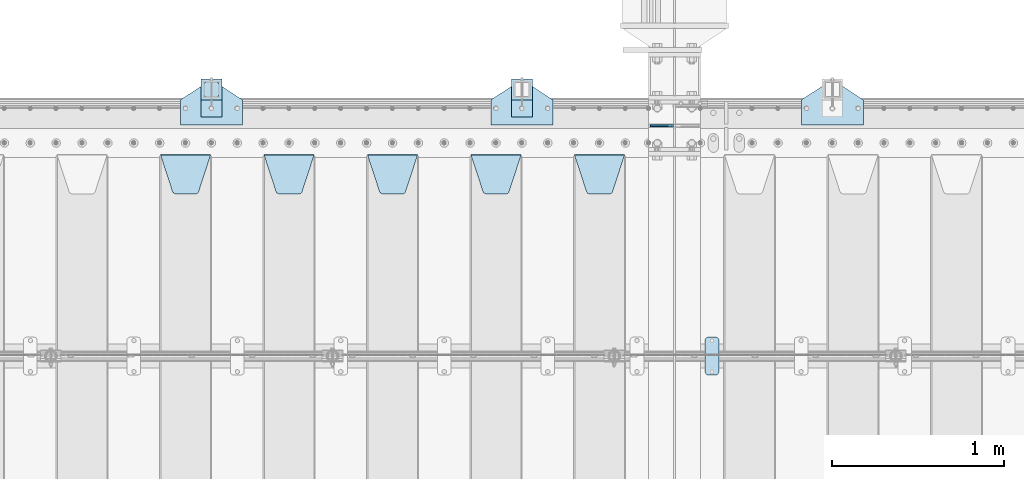
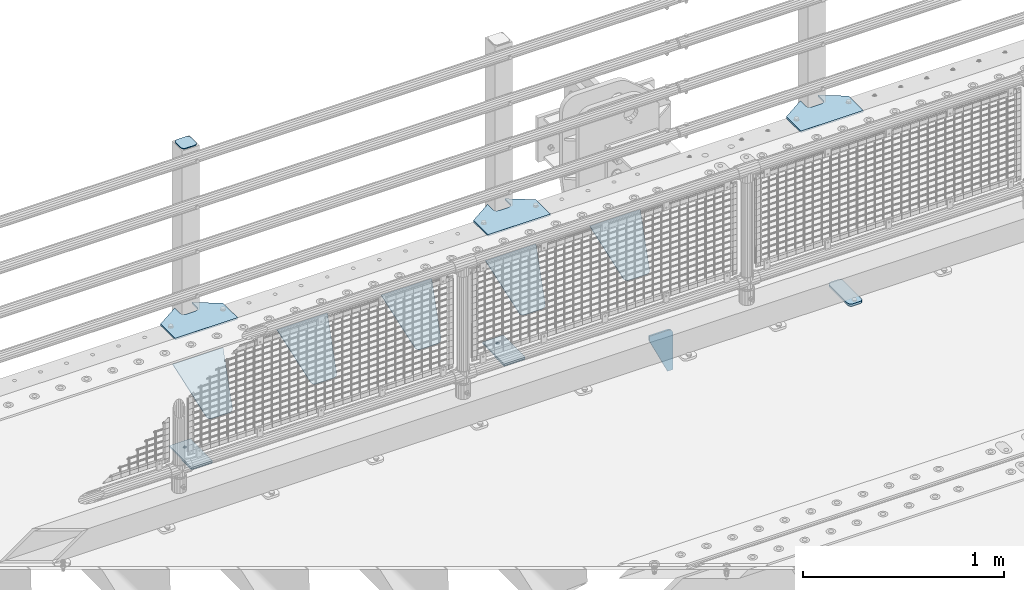
# One storey, part 215 of 242: 15 plates.
"""IFC2X3 building model written with IfcOpenShell, lengths in millimetres."""

from ifc_helpers import new_model, si_unit, frame, origin_with_axes, place, context, subcontext, project, spatial, faceted_brep, material, type_object, element, save


model = new_model("IFC2X3")

# Units and contexts
model_context = context("Model", 3, precision=1e-05, world=origin_with_axes())
body_context = subcontext(model_context, "Body", "Model", "MODEL_VIEW")
ifc_project = project(units=[si_unit("LENGTHUNIT", "METRE", prefix="MILLI"), si_unit("AREAUNIT", "SQUARE_METRE"), si_unit("VOLUMEUNIT", "CUBIC_METRE"), si_unit("MASSUNIT", "GRAM", prefix="KILO"), si_unit("TIMEUNIT", "SECOND"), si_unit("PLANEANGLEUNIT", "RADIAN"), si_unit("SOLIDANGLEUNIT", "STERADIAN"), si_unit("THERMODYNAMICTEMPERATUREUNIT", "DEGREE_CELSIUS"), si_unit("LUMINOUSINTENSITYUNIT", "LUMEN")], contexts=[model_context])

# Site, building, storey
site_placement = place(None, origin_with_axes())
site = spatial("IfcSite", under=ifc_project, at=site_placement, CompositionType="ELEMENT")
building_placement = place(site_placement, origin_with_axes())
building = spatial("IfcBuilding", under=site, at=building_placement, Name="Standard", CompositionType="ELEMENT")
storey_placement = place(building_placement, origin_with_axes())
storey = spatial("IfcBuildingStorey", under=building, at=storey_placement, Name="Undefined", CompositionType="ELEMENT", Elevation=0.0)

# Plates
ifc_material_1 = material(Name="STEEL/S355J2")
plate_type_1 = type_object("IfcPlateType", PredefinedType="NOTDEFINED")
plate_1_placement = place(storey_placement, frame((-28238.0, -19225.5, 21.0199999999977), z_axis=(1.0, 0.0, 0.0), x_axis=(0.0, -1.0, 0.0)))
element("IfcPlate", 1, at=plate_1_placement, inside=storey, type_object=plate_type_1, material=ifc_material_1, context=body_context, shape_type="Brep", body=[
    faceted_brep([(0.0, -7.0, 20.0), (0.0, -7.0, 60.0), (0.0, 7.0, 60.0), (0.0, 7.0, 20.0), (0.384294391937146, -7.0, 63.9018064403208), (0.384294391937146, 7.0, 63.9018064403208), (1.52240934977453, -7.0, 67.6536686473009), (1.52240934977453, 7.0, 67.6536686473009), (3.37060775395003, -7.0, 71.1114046603907), (3.37060775395003, 7.0, 71.1114046603907), (5.8578643762703, -7.0, 74.1421356237297), (5.8578643762703, 7.0, 74.1421356237297), (8.88859533960931, -7.0, 76.62939224605), (8.88859533960931, 7.0, 76.62939224605), (12.3463313526991, -7.0, 78.4775906502255), (12.3463313526991, 7.0, 78.4775906502255), (16.0981935596792, -7.0, 79.6157056080629), (16.0981935596792, 7.0, 79.6157056080629), (20.0, -7.0, 80.0), (20.0, 7.0, 80.0), (200.0, -7.0, 80.0), (200.0, 7.0, 80.0), (203.901806440321, -7.0, 79.6157056080629), (203.901806440321, 7.0, 79.6157056080629), (207.653668647301, -7.0, 78.4775906502255), (207.653668647301, 7.0, 78.4775906502255), (211.111404660391, -7.0, 76.62939224605), (211.111404660391, 7.0, 76.62939224605), (214.14213562373, -7.0, 74.1421356237297), (214.14213562373, 7.0, 74.1421356237297), (216.62939224605, -7.0, 71.1114046603907), (216.62939224605, 7.0, 71.1114046603907), (218.477590650225, -7.0, 67.6536686473009), (218.477590650225, 7.0, 67.6536686473009), (219.615705608063, -7.0, 63.9018064403208), (219.615705608063, 7.0, 63.9018064403208), (220.0, -7.0, 60.0), (220.0, 7.0, 60.0), (220.0, -7.0, 20.0), (220.0, 7.0, 20.0), (219.615705608063, -7.0, 16.0981935596792), (219.615705608063, 7.0, 16.0981935596792), (218.477590650225, -7.0, 12.3463313526991), (218.477590650225, 7.0, 12.3463313526991), (216.62939224605, -7.0, 8.88859533960931), (216.62939224605, 7.0, 8.88859533960931), (214.14213562373, -7.0, 5.8578643762703), (214.14213562373, 7.0, 5.8578643762703), (211.111404660391, -7.0, 3.37060775395003), (211.111404660391, 7.0, 3.37060775395003), (207.653668647301, -7.0, 1.52240934977453), (207.653668647301, 7.0, 1.52240934977453), (203.901806440321, -7.0, 0.384294391937146), (203.901806440321, 7.0, 0.384294391937146), (200.0, -7.0, 0.0), (200.0, 7.0, 0.0), (20.0, -7.0, 0.0), (20.0, 7.0, 0.0), (16.0981935596792, -7.0, 0.384294391937146), (16.0981935596792, 7.0, 0.384294391937146), (12.3463313526991, -7.0, 1.52240934977453), (12.3463313526991, 7.0, 1.52240934977453), (8.88859533960931, -7.0, 3.37060775395003), (8.88859533960931, 7.0, 3.37060775395003), (5.8578643762703, -7.0, 5.8578643762703), (5.8578643762703, 7.0, 5.8578643762703), (3.37060775395003, -7.0, 8.88859533960931), (3.37060775395003, 7.0, 8.88859533960931), (1.52240934977453, -7.0, 12.3463313526991), (1.52240934977453, 7.0, 12.3463313526991), (0.384294391937146, -7.0, 16.0981935596792), (0.384294391937146, 7.0, 16.0981935596792)], [[[0, 1, 2, 3]], [[1, 4, 5, 2]], [[4, 6, 7, 5]], [[6, 8, 9, 7]], [[8, 10, 11, 9]], [[10, 12, 13, 11]], [[12, 14, 15, 13]], [[14, 16, 17, 15]], [[16, 18, 19, 17]], [[18, 20, 21, 19]], [[20, 22, 23, 21]], [[22, 24, 25, 23]], [[24, 26, 27, 25]], [[26, 28, 29, 27]], [[28, 30, 31, 29]], [[30, 32, 33, 31]], [[32, 34, 35, 33]], [[34, 36, 37, 35]], [[36, 38, 39, 37]], [[38, 40, 41, 39]], [[40, 42, 43, 41]], [[42, 44, 45, 43]], [[44, 46, 47, 45]], [[46, 48, 49, 47]], [[48, 50, 51, 49]], [[50, 52, 53, 51]], [[52, 54, 55, 53]], [[54, 56, 57, 55]], [[56, 58, 59, 57]], [[58, 60, 61, 59]], [[60, 62, 63, 61]], [[62, 64, 65, 63]], [[64, 66, 67, 65]], [[66, 68, 69, 67]], [[68, 70, 71, 69]], [[70, 0, 3, 71]], [[5, 7, 9, 11, 13, 15, 17, 19, 21, 23, 25, 27, 29, 31, 33, 35, 37, 39, 41, 43, 45, 47, 49, 51, 53, 55, 57, 59, 61, 63, 65, 67, 69, 71, 3, 2]], [[70, 68, 66, 64, 62, 60, 58, 56, 54, 52, 50, 48, 46, 44, 42, 40, 38, 36, 34, 32, 30, 28, 26, 24, 22, 20, 18, 16, 14, 12, 10, 8, 6, 4, 1, 0]]]),
])
plate_type_2 = type_object("IfcPlateType", PredefinedType="NOTDEFINED")
plate_2_placement = place(storey_placement, frame((-27680.0, -17995.0, 5.00000000004911), z_axis=(0.0, 1.0, 0.0), x_axis=(1.0, 0.0, 0.0)))
element("IfcPlate", 2, at=plate_2_placement, inside=storey, type_object=plate_type_2, material=ifc_material_1, context=body_context, shape_type="Brep", body=[
    faceted_brep([(0.0, -5.0, 0.0), (2.31396552408114e-06, -5.0, 145.0), (2.31396552408114e-06, 5.0, 145.0), (0.0, 5.0, 0.0), (130.0, -5.0, 230.0), (130.0, 5.0, 230.0), (130.0, -5.0, 180.0), (130.0, 5.0, 180.0), (130.48036798992, -5.0, 175.122741949595), (130.48036798992, 5.0, 175.122741949595), (131.903011687216, -5.0, 170.432914190871), (131.903011687216, 5.0, 170.432914190871), (134.213259692435, -5.0, 166.110744174512), (134.213259692435, 5.0, 166.110744174512), (137.322330470335, -5.0, 162.322330470335), (137.322330470335, 5.0, 162.322330470335), (141.110744174512, -5.0, 159.213259692435), (141.110744174512, 5.0, 159.213259692435), (145.432914190871, -5.0, 156.903011687216), (145.432914190871, 5.0, 156.903011687216), (150.122741949595, -5.0, 155.48036798992), (150.122741949595, 5.0, 155.48036798992), (155.0, -5.0, 155.0), (155.0, 5.0, 155.0), (205.0, -5.0, 155.0), (205.0, 5.0, 155.0), (209.877258050405, -5.0, 155.48036798992), (209.877258050405, 5.0, 155.48036798992), (214.567085809129, -5.0, 156.903011687216), (214.567085809129, 5.0, 156.903011687216), (218.889255825488, -5.0, 159.213259692435), (218.889255825488, 5.0, 159.213259692435), (222.677669529665, -5.0, 162.322330470335), (222.677669529665, 5.0, 162.322330470335), (225.786740307565, -5.0, 166.110744174512), (225.786740307565, 5.0, 166.110744174512), (228.096988312784, -5.0, 170.432914190871), (228.096988312784, 5.0, 170.432914190871), (229.51963201008, -5.0, 175.122741949595), (229.51963201008, 5.0, 175.122741949595), (230.0, -5.0, 180.0), (230.0, 5.0, 180.0), (230.0, -5.0, 230.0), (230.0, 5.0, 230.0), (360.0, -5.0, 145.0), (360.0, 5.0, 145.0), (360.0, -5.0, -7.27595761418343e-12), (360.0, 5.0, -7.27595761418343e-12)], [[[0, 1, 2, 3]], [[1, 4, 5, 2]], [[4, 6, 7, 5]], [[6, 8, 9, 7]], [[8, 10, 11, 9]], [[10, 12, 13, 11]], [[12, 14, 15, 13]], [[14, 16, 17, 15]], [[16, 18, 19, 17]], [[18, 20, 21, 19]], [[20, 22, 23, 21]], [[22, 24, 25, 23]], [[24, 26, 27, 25]], [[26, 28, 29, 27]], [[28, 30, 31, 29]], [[30, 32, 33, 31]], [[32, 34, 35, 33]], [[34, 36, 37, 35]], [[36, 38, 39, 37]], [[38, 40, 41, 39]], [[40, 42, 43, 41]], [[42, 44, 45, 43]], [[44, 46, 47, 45]], [[46, 0, 3, 47]], [[5, 7, 9, 11, 13, 15, 17, 19, 21, 23, 25, 27, 29, 31, 33, 35, 37, 39, 41, 43, 45, 47, 3, 2]], [[46, 44, 42, 40, 38, 36, 34, 32, 30, 28, 26, 24, 22, 20, 18, 16, 14, 12, 10, 8, 6, 4, 1, 0]]]),
])
plate_3_placement = place(storey_placement, frame((-29480.0, -17995.0, 5.00000000004911), z_axis=(0.0, 1.0, 0.0), x_axis=(1.0, 0.0, 0.0)))
element("IfcPlate", 3, at=plate_3_placement, inside=storey, type_object=plate_type_2, material=ifc_material_1, context=body_context, shape_type="Brep", body=[
    faceted_brep([(0.0, -5.0, 0.0), (2.31396552408114e-06, -5.0, 145.0), (2.31396552408114e-06, 5.0, 145.0), (0.0, 5.0, 0.0), (130.0, -5.0, 230.0), (130.0, 5.0, 230.0), (130.0, -5.0, 180.0), (130.0, 5.0, 180.0), (130.48036798992, -5.0, 175.122741949595), (130.48036798992, 5.0, 175.122741949595), (131.903011687216, -5.0, 170.432914190871), (131.903011687216, 5.0, 170.432914190871), (134.213259692435, -5.0, 166.110744174512), (134.213259692435, 5.0, 166.110744174512), (137.322330470335, -5.0, 162.322330470335), (137.322330470335, 5.0, 162.322330470335), (141.110744174512, -5.0, 159.213259692435), (141.110744174512, 5.0, 159.213259692435), (145.432914190871, -5.0, 156.903011687216), (145.432914190871, 5.0, 156.903011687216), (150.122741949595, -5.0, 155.48036798992), (150.122741949595, 5.0, 155.48036798992), (155.0, -5.0, 155.0), (155.0, 5.0, 155.0), (205.0, -5.0, 155.0), (205.0, 5.0, 155.0), (209.877258050405, -5.0, 155.48036798992), (209.877258050405, 5.0, 155.48036798992), (214.567085809129, -5.0, 156.903011687216), (214.567085809129, 5.0, 156.903011687216), (218.889255825488, -5.0, 159.213259692435), (218.889255825488, 5.0, 159.213259692435), (222.677669529665, -5.0, 162.322330470335), (222.677669529665, 5.0, 162.322330470335), (225.786740307565, -5.0, 166.110744174512), (225.786740307565, 5.0, 166.110744174512), (228.096988312784, -5.0, 170.432914190871), (228.096988312784, 5.0, 170.432914190871), (229.51963201008, -5.0, 175.122741949595), (229.51963201008, 5.0, 175.122741949595), (230.0, -5.0, 180.0), (230.0, 5.0, 180.0), (230.0, -5.0, 230.0), (230.0, 5.0, 230.0), (360.0, -5.0, 145.0), (360.0, 5.0, 145.0), (360.0, -5.0, -7.27595761418343e-12), (360.0, 5.0, -7.27595761418343e-12)], [[[0, 1, 2, 3]], [[1, 4, 5, 2]], [[4, 6, 7, 5]], [[6, 8, 9, 7]], [[8, 10, 11, 9]], [[10, 12, 13, 11]], [[12, 14, 15, 13]], [[14, 16, 17, 15]], [[16, 18, 19, 17]], [[18, 20, 21, 19]], [[20, 22, 23, 21]], [[22, 24, 25, 23]], [[24, 26, 27, 25]], [[26, 28, 29, 27]], [[28, 30, 31, 29]], [[30, 32, 33, 31]], [[32, 34, 35, 33]], [[34, 36, 37, 35]], [[36, 38, 39, 37]], [[38, 40, 41, 39]], [[40, 42, 43, 41]], [[42, 44, 45, 43]], [[44, 46, 47, 45]], [[46, 0, 3, 47]], [[5, 7, 9, 11, 13, 15, 17, 19, 21, 23, 25, 27, 29, 31, 33, 35, 37, 39, 41, 43, 45, 47, 3, 2]], [[46, 44, 42, 40, 38, 36, 34, 32, 30, 28, 26, 24, 22, 20, 18, 16, 14, 12, 10, 8, 6, 4, 1, 0]]]),
])
plate_4_placement = place(storey_placement, frame((-31280.0, -17995.0, 5.00000000004911), z_axis=(0.0, 1.0, 0.0), x_axis=(1.0, 0.0, 0.0)))
element("IfcPlate", 4, at=plate_4_placement, inside=storey, type_object=plate_type_2, material=ifc_material_1, context=body_context, shape_type="Brep", body=[
    faceted_brep([(0.0, -5.0, 0.0), (2.31396552408114e-06, -5.0, 145.0), (2.31396552408114e-06, 5.0, 145.0), (0.0, 5.0, 0.0), (130.0, -5.0, 230.0), (130.0, 5.0, 230.0), (130.0, -5.0, 180.0), (130.0, 5.0, 180.0), (130.48036798992, -5.0, 175.122741949595), (130.48036798992, 5.0, 175.122741949595), (131.903011687216, -5.0, 170.432914190871), (131.903011687216, 5.0, 170.432914190871), (134.213259692435, -5.0, 166.110744174512), (134.213259692435, 5.0, 166.110744174512), (137.322330470335, -5.0, 162.322330470335), (137.322330470335, 5.0, 162.322330470335), (141.110744174512, -5.0, 159.213259692435), (141.110744174512, 5.0, 159.213259692435), (145.432914190871, -5.0, 156.903011687216), (145.432914190871, 5.0, 156.903011687216), (150.122741949595, -5.0, 155.48036798992), (150.122741949595, 5.0, 155.48036798992), (155.0, -5.0, 155.0), (155.0, 5.0, 155.0), (205.0, -5.0, 155.0), (205.0, 5.0, 155.0), (209.877258050405, -5.0, 155.48036798992), (209.877258050405, 5.0, 155.48036798992), (214.567085809129, -5.0, 156.903011687216), (214.567085809129, 5.0, 156.903011687216), (218.889255825488, -5.0, 159.213259692435), (218.889255825488, 5.0, 159.213259692435), (222.677669529665, -5.0, 162.322330470335), (222.677669529665, 5.0, 162.322330470335), (225.786740307565, -5.0, 166.110744174512), (225.786740307565, 5.0, 166.110744174512), (228.096988312784, -5.0, 170.432914190871), (228.096988312784, 5.0, 170.432914190871), (229.51963201008, -5.0, 175.122741949595), (229.51963201008, 5.0, 175.122741949595), (230.0, -5.0, 180.0), (230.0, 5.0, 180.0), (230.0, -5.0, 230.0), (230.0, 5.0, 230.0), (360.0, -5.0, 145.0), (360.0, 5.0, 145.0), (360.0, -5.0, -7.27595761418343e-12), (360.0, 5.0, -7.27595761418343e-12)], [[[0, 1, 2, 3]], [[1, 4, 5, 2]], [[4, 6, 7, 5]], [[6, 8, 9, 7]], [[8, 10, 11, 9]], [[10, 12, 13, 11]], [[12, 14, 15, 13]], [[14, 16, 17, 15]], [[16, 18, 19, 17]], [[18, 20, 21, 19]], [[20, 22, 23, 21]], [[22, 24, 25, 23]], [[24, 26, 27, 25]], [[26, 28, 29, 27]], [[28, 30, 31, 29]], [[30, 32, 33, 31]], [[32, 34, 35, 33]], [[34, 36, 37, 35]], [[36, 38, 39, 37]], [[38, 40, 41, 39]], [[40, 42, 43, 41]], [[42, 44, 45, 43]], [[44, 46, 47, 45]], [[46, 0, 3, 47]], [[5, 7, 9, 11, 13, 15, 17, 19, 21, 23, 25, 27, 29, 31, 33, 35, 37, 39, 41, 43, 45, 47, 3, 2]], [[46, 44, 42, 40, 38, 36, 34, 32, 30, 28, 26, 24, 22, 20, 18, 16, 14, 12, 10, 8, 6, 4, 1, 0]]]),
])
plate_type_3 = type_object("IfcPlateType", PredefinedType="NOTDEFINED")
for number, where, z_axis, x_axis in (
    (5, (-29359.9999999999, -17949.9999999998, -850.000000000002), (0.0, 1.0, 0.0), (1.0, 0.0, 0.0)),
    (6, (-31159.9999999999, -17949.9999999998, -850.000000000002), (0.0, 1.0, 0.0), (1.0, 0.0, 0.0)),
):
    element("IfcPlate", number, at=place(storey_placement, frame(where, z_axis=z_axis, x_axis=x_axis)), inside=storey, type_object=plate_type_3, material=ifc_material_1, context=body_context, shape_type="Brep", body=[
        faceted_brep([(66.3639610305399, -5.0, 163.636038969114), (66.3639610305399, 5.0, 163.636038969114), (59.9999999998618, 5.0, 160.999999999793), (59.9999999998618, -5.0, 160.999999999793), (53.6360389691836, 5.0, 163.636038969114), (53.6360389691836, -5.0, 163.636038969114), (50.9999999998618, 5.0, 169.999999999793), (50.9999999998618, -5.0, 169.999999999793), (53.6360389691836, 5.0, 176.363961030471), (53.6360389691836, -5.0, 176.363961030471), (59.9999999998618, 5.0, 178.999999999793), (59.9999999998618, -5.0, 178.999999999793), (66.3639610305399, 5.0, 176.363961030471), (66.3639610305399, -5.0, 176.363961030471), (68.9999999998618, 5.0, 169.999999999793), (68.9999999998618, -5.0, 169.999999999793), (120.0, -5.0, 0.0), (120.0, -5.0, 220.0), (0.0, -5.0, 220.0), (0.0, -5.0, 0.0), (0.0, 5.0, 0.0), (120.0, 5.0, 0.0), (120.0, 5.0, 220.0), (0.0, 5.0, 220.0)], [[[0, 1, 2, 3]], [[3, 2, 4, 5]], [[5, 4, 6, 7]], [[7, 6, 8, 9]], [[9, 8, 10, 11]], [[11, 10, 12, 13]], [[13, 12, 14, 15]], [[15, 14, 1, 0]], [[16, 17, 18, 19], [11, 13, 15, 0, 3, 5, 7, 9]], [[16, 19, 20, 21]], [[17, 16, 21, 22]], [[18, 17, 22, 23]], [[19, 18, 23, 20]], [[22, 21, 20, 23], [2, 1, 14, 12, 10, 8, 6, 4]]]),
    ])
plate_type_4 = type_object("IfcPlateType", PredefinedType="NOTDEFINED")
plate_5_placement = place(storey_placement, frame((-31055.9999999999, -17833.9999999998, 1012.50000000001), z_axis=(0.0, 1.0, 0.0), x_axis=(-1.0, 0.0, 0.0)))
element("IfcPlate", 7, at=plate_5_placement, inside=storey, type_object=plate_type_4, material=ifc_material_1, context=body_context, shape_type="Brep", body=[
    faceted_brep([(0.0, -2.5, 19.0), (0.0, -2.5, 69.0), (0.0, 2.5, 69.0), (0.0, 2.5, 19.0), (0.476369668544066, -2.5, 73.2278977451715), (0.476369668544066, 2.5, 73.2278977451715), (1.88159150985302, -2.5, 77.2437910432345), (1.88159150985302, 2.5, 77.2437910432345), (4.14520183310742, -2.5, 80.8463062353148), (4.14520183310742, 2.5, 80.8463062353148), (7.15369376468516, -2.5, 83.8547981668926), (7.15369376468516, 2.5, 83.8547981668926), (10.7562089567655, -2.5, 86.118408490147), (10.7562089567655, 2.5, 86.118408490147), (14.7721022548285, -2.5, 87.5236303314559), (14.7721022548285, 2.5, 87.5236303314559), (19.0, -2.5, 88.0), (19.0, 2.5, 88.0), (69.0, -2.5, 88.0), (69.0, 2.5, 88.0), (73.2278977451715, -2.5, 87.5236303314559), (73.2278977451715, 2.5, 87.5236303314559), (77.2437910432345, -2.5, 86.118408490147), (77.2437910432345, 2.5, 86.118408490147), (80.8463062353148, -2.5, 83.8547981668926), (80.8463062353148, 2.5, 83.8547981668926), (83.8547981668926, -2.5, 80.8463062353148), (83.8547981668926, 2.5, 80.8463062353148), (86.118408490147, -2.5, 77.2437910432345), (86.118408490147, 2.5, 77.2437910432345), (87.5236303314559, -2.5, 73.2278977451715), (87.5236303314559, 2.5, 73.2278977451715), (88.0, -2.5, 69.0), (88.0, 2.5, 69.0), (88.0, -2.5, 19.0), (88.0, 2.5, 19.0), (87.5236303314559, -2.5, 14.7721022548285), (87.5236303314559, 2.5, 14.7721022548285), (86.118408490147, -2.5, 10.7562089567655), (86.118408490147, 2.5, 10.7562089567655), (83.8547981668926, -2.5, 7.15369376468516), (83.8547981668926, 2.5, 7.15369376468516), (80.8463062353148, -2.5, 4.14520183310742), (80.8463062353148, 2.5, 4.14520183310742), (77.2437910432345, -2.5, 1.88159150985302), (77.2437910432345, 2.5, 1.88159150985302), (73.2278977451715, -2.5, 0.476369668544066), (73.2278977451715, 2.5, 0.476369668544066), (69.0, -2.5, 0.0), (69.0, 2.5, 0.0), (19.0, -2.5, 0.0), (19.0, 2.5, 0.0), (14.7721022548285, -2.5, 0.476369668544066), (14.7721022548285, 2.5, 0.476369668544066), (10.7562089567655, -2.5, 1.88159150985302), (10.7562089567655, 2.5, 1.88159150985302), (7.15369376468516, -2.5, 4.14520183310742), (7.15369376468516, 2.5, 4.14520183310742), (4.14520183310742, -2.5, 7.15369376468516), (4.14520183310742, 2.5, 7.15369376468516), (1.88159150985302, -2.5, 10.7562089567655), (1.88159150985302, 2.5, 10.7562089567655), (0.476369668544066, -2.5, 14.7721022548285), (0.476369668544066, 2.5, 14.7721022548285)], [[[0, 1, 2, 3]], [[1, 4, 5, 2]], [[4, 6, 7, 5]], [[6, 8, 9, 7]], [[8, 10, 11, 9]], [[10, 12, 13, 11]], [[12, 14, 15, 13]], [[14, 16, 17, 15]], [[16, 18, 19, 17]], [[18, 20, 21, 19]], [[20, 22, 23, 21]], [[22, 24, 25, 23]], [[24, 26, 27, 25]], [[26, 28, 29, 27]], [[28, 30, 31, 29]], [[30, 32, 33, 31]], [[32, 34, 35, 33]], [[34, 36, 37, 35]], [[36, 38, 39, 37]], [[38, 40, 41, 39]], [[40, 42, 43, 41]], [[42, 44, 45, 43]], [[44, 46, 47, 45]], [[46, 48, 49, 47]], [[48, 50, 51, 49]], [[50, 52, 53, 51]], [[52, 54, 55, 53]], [[54, 56, 57, 55]], [[56, 58, 59, 57]], [[58, 60, 61, 59]], [[60, 62, 63, 61]], [[62, 0, 3, 63]], [[5, 7, 9, 11, 13, 15, 17, 19, 21, 23, 25, 27, 29, 31, 33, 35, 37, 39, 41, 43, 45, 47, 49, 51, 53, 55, 57, 59, 61, 63, 3, 2]], [[62, 60, 58, 56, 54, 52, 50, 48, 46, 44, 42, 40, 38, 36, 34, 32, 30, 28, 26, 24, 22, 20, 18, 16, 14, 12, 10, 8, 6, 4, 1, 0]]]),
])
plate_type_5 = type_object("IfcPlateType", PredefinedType="NOTDEFINED")
for number, where, z_axis, x_axis in (
    (8, (-29359.9999999999, -17949.9999999998, -857.500000000002), (0.0, 1.0, 0.0), (1.0, 0.0, 0.0)),
    (9, (-31159.9999999999, -17949.9999999998, -857.500000000002), (0.0, 1.0, 0.0), (1.0, 0.0, 0.0)),
):
    element("IfcPlate", number, at=place(storey_placement, frame(where, z_axis=z_axis, x_axis=x_axis)), inside=storey, type_object=plate_type_5, material=ifc_material_1, context=body_context, shape_type="Brep", body=[
        faceted_brep([(0.0, -2.5, 0.0), (0.0, -2.5, 100.0), (0.0, 2.5, 100.0), (0.0, 2.5, 0.0), (120.0, -2.5, 100.0), (120.0, 2.5, 100.0), (120.0, -2.5, 0.0), (120.0, 2.5, 0.0)], [[[0, 1, 2, 3]], [[1, 4, 5, 2]], [[4, 6, 7, 5]], [[6, 0, 3, 7]], [[5, 7, 3, 2]], [[6, 4, 1, 0]]]),
    ])
ifc_material_2 = material(Name="STEEL/S355N")
plate_type_6 = type_object("IfcPlateType", PredefinedType="NOTDEFINED")
plate_6_placement = place(storey_placement, frame((-28421.4999999426, -18000.0000000349, -925.000018222556), z_axis=(0.0, 0.0, -1.0), x_axis=(-1.0, 0.0, 0.0)))
element("IfcPlate", 10, at=plate_6_placement, inside=storey, type_object=plate_type_6, material=ifc_material_2, context=body_context, shape_type="Brep", body=[
    faceted_brep([(0.0, -5.0, 27.0), (0.0, -5.0, 250.0), (0.0, 5.0, 250.0), (0.0, 5.0, 27.0), (30.0, -5.0, 250.0), (30.0, 5.0, 250.0), (135.0, -5.0, 30.0), (135.0, 5.0, 30.0), (135.0, -5.0, 0.0), (135.0, 5.0, 0.0), (27.0, -5.0, 0.0), (27.0, 5.0, 0.0), (22.3114992029914, -5.0, 0.410190668670339), (22.3114992029914, 5.0, 0.410190668670339), (17.7654561302079, -5.0, 1.62829923878041), (17.7654561302079, 5.0, 1.62829923878041), (13.5, -5.0, 3.61731409782021), (13.5, 5.0, 3.61731409782021), (9.64473453846222, -5.0, 6.31680003578765), (9.64473453846222, 5.0, 6.31680003578765), (6.31680003578731, -5.0, 9.64473453846347), (6.31680003578731, 5.0, 9.64473453846347), (3.61731409782078, -5.0, 13.5), (3.61731409782078, 5.0, 13.5), (1.62829923877871, -5.0, 17.765456130207), (1.62829923877871, 5.0, 17.765456130207), (0.410190668670111, -5.0, 22.3114992029929), (0.410190668670111, 5.0, 22.3114992029929)], [[[0, 1, 2, 3]], [[1, 4, 5, 2]], [[4, 6, 7, 5]], [[6, 8, 9, 7]], [[8, 10, 11, 9]], [[10, 12, 13, 11]], [[12, 14, 15, 13]], [[14, 16, 17, 15]], [[16, 18, 19, 17]], [[18, 20, 21, 19]], [[20, 22, 23, 21]], [[22, 24, 25, 23]], [[24, 26, 27, 25]], [[26, 0, 3, 27]], [[5, 7, 9, 11, 13, 15, 17, 19, 21, 23, 25, 27, 3, 2]], [[26, 24, 22, 20, 18, 16, 14, 12, 10, 8, 6, 4, 1, 0]]]),
])
plate_type_7 = type_object("IfcPlateType", PredefinedType="NOTDEFINED")
plate_7_placement = place(storey_placement, frame((-28995.0, -18168.2322330441, -1.76776695296576), z_axis=(0.0, -0.707106781186547, -0.707106781186548), x_axis=(1.0, 0.0, 0.0)))
element("IfcPlate", 11, at=plate_7_placement, inside=storey, type_object=plate_type_7, material=ifc_material_2, context=body_context, shape_type="Brep", body=[
    faceted_brep([(0.0, -2.5, 0.0), (69.345504679477, -2.50000000000182, 300.171731424829), (69.345504679477, 2.5, 300.171731424829), (0.0, 2.5, 0.0), (70.9274061199576, -2.5, 304.897442415398), (70.9274061199576, 2.5, 304.897442415398), (73.3818627772307, -2.5, 309.234538108525), (73.3818627772307, 2.50000000000182, 309.234538108529), (76.6187032999551, -2.5, 313.023683126101), (76.6187032999551, 2.50000000000182, 313.023683126103), (80.5190132704993, -2.5, 316.12567259537), (80.5190132704993, 2.5, 316.12567259537), (84.9395038596849, -2.5, 318.426546230474), (84.9395038596849, 2.50000000000182, 318.426546230476), (89.7177759439219, -2.49999999999818, 319.841774983273), (89.7177759439219, 2.50000000000182, 319.841774983273), (94.678286292652, -2.5, 320.319366455076), (94.678286292652, 2.5, 320.319366455076), (195.321713707348, -2.5, 320.319366455076), (195.321713707348, 2.5, 320.319366455076), (200.282224056078, -2.5, 319.841774983272), (200.282224056078, 2.50000000000182, 319.841774983273), (205.060496140315, -2.5, 318.426546230474), (205.060496140315, 2.49999999999818, 318.426546230474), (209.480986729501, -2.49999999999818, 316.12567259537), (209.480986729501, 2.5, 316.12567259537), (213.381296700045, -2.5, 313.023683126101), (213.381296700045, 2.49999999999818, 313.023683126101), (216.618137222769, -2.5, 309.234538108525), (216.618137222769, 2.5, 309.234538108523), (219.072593880042, -2.49999999999818, 304.897442415398), (219.072593880042, 2.50000000000182, 304.897442415398), (220.654495320523, -2.50000000000182, 300.171731424829), (220.654495320523, 2.5, 300.171731424829), (290.0, -2.5, 0.0), (290.0, 2.5, -1.81898940354586e-12)], [[[0, 1, 2, 3]], [[1, 4, 5, 2]], [[4, 6, 7, 5]], [[6, 8, 9, 7]], [[8, 10, 11, 9]], [[10, 12, 13, 11]], [[12, 14, 15, 13]], [[14, 16, 17, 15]], [[16, 18, 19, 17]], [[18, 20, 21, 19]], [[20, 22, 23, 21]], [[22, 24, 25, 23]], [[24, 26, 27, 25]], [[26, 28, 29, 27]], [[28, 30, 31, 29]], [[30, 32, 33, 31]], [[32, 34, 35, 33]], [[34, 0, 3, 35]], [[5, 7, 9, 11, 13, 15, 17, 19, 21, 23, 25, 27, 29, 31, 33, 35, 3, 2]], [[34, 32, 30, 28, 26, 24, 22, 20, 18, 16, 14, 12, 10, 8, 6, 4, 1, 0]]]),
])
plate_8_placement = place(storey_placement, frame((-29595.0, -18168.2322330441, -1.76776695296576), z_axis=(0.0, -0.707106781186547, -0.707106781186548), x_axis=(1.0, 0.0, 0.0)))
element("IfcPlate", 12, at=plate_8_placement, inside=storey, type_object=plate_type_7, material=ifc_material_2, context=body_context, shape_type="Brep", body=[
    faceted_brep([(0.0, -2.5, 0.0), (69.345504679477, -2.50000000000182, 300.171731424829), (69.345504679477, 2.5, 300.171731424829), (0.0, 2.5, 0.0), (70.9274061199576, -2.5, 304.897442415398), (70.9274061199576, 2.5, 304.897442415398), (73.3818627772307, -2.5, 309.234538108525), (73.3818627772307, 2.50000000000182, 309.234538108529), (76.6187032999551, -2.5, 313.023683126101), (76.6187032999551, 2.50000000000182, 313.023683126103), (80.5190132704993, -2.5, 316.12567259537), (80.5190132704993, 2.5, 316.12567259537), (84.9395038596849, -2.5, 318.426546230474), (84.9395038596849, 2.50000000000182, 318.426546230476), (89.7177759439219, -2.49999999999818, 319.841774983273), (89.7177759439219, 2.50000000000182, 319.841774983273), (94.678286292652, -2.5, 320.319366455076), (94.678286292652, 2.5, 320.319366455076), (195.321713707348, -2.5, 320.319366455076), (195.321713707348, 2.5, 320.319366455076), (200.282224056078, -2.5, 319.841774983272), (200.282224056078, 2.50000000000182, 319.841774983273), (205.060496140315, -2.5, 318.426546230474), (205.060496140315, 2.49999999999818, 318.426546230474), (209.480986729501, -2.49999999999818, 316.12567259537), (209.480986729501, 2.5, 316.12567259537), (213.381296700045, -2.5, 313.023683126101), (213.381296700045, 2.49999999999818, 313.023683126101), (216.618137222769, -2.5, 309.234538108525), (216.618137222769, 2.5, 309.234538108523), (219.072593880042, -2.49999999999818, 304.897442415398), (219.072593880042, 2.50000000000182, 304.897442415398), (220.654495320523, -2.50000000000182, 300.171731424829), (220.654495320523, 2.5, 300.171731424829), (290.0, -2.5, 0.0), (290.0, 2.5, -1.81898940354586e-12)], [[[0, 1, 2, 3]], [[1, 4, 5, 2]], [[4, 6, 7, 5]], [[6, 8, 9, 7]], [[8, 10, 11, 9]], [[10, 12, 13, 11]], [[12, 14, 15, 13]], [[14, 16, 17, 15]], [[16, 18, 19, 17]], [[18, 20, 21, 19]], [[20, 22, 23, 21]], [[22, 24, 25, 23]], [[24, 26, 27, 25]], [[26, 28, 29, 27]], [[28, 30, 31, 29]], [[30, 32, 33, 31]], [[32, 34, 35, 33]], [[34, 0, 3, 35]], [[5, 7, 9, 11, 13, 15, 17, 19, 21, 23, 25, 27, 29, 31, 33, 35, 3, 2]], [[34, 32, 30, 28, 26, 24, 22, 20, 18, 16, 14, 12, 10, 8, 6, 4, 1, 0]]]),
])
plate_9_placement = place(storey_placement, frame((-30195.0, -18168.2322330441, -1.76776695296576), z_axis=(0.0, -0.707106781186547, -0.707106781186548), x_axis=(1.0, 0.0, 0.0)))
element("IfcPlate", 13, at=plate_9_placement, inside=storey, type_object=plate_type_7, material=ifc_material_2, context=body_context, shape_type="Brep", body=[
    faceted_brep([(0.0, -2.5, 0.0), (69.345504679477, -2.50000000000182, 300.171731424829), (69.345504679477, 2.5, 300.171731424829), (0.0, 2.5, 0.0), (70.9274061199576, -2.5, 304.897442415398), (70.9274061199576, 2.5, 304.897442415398), (73.3818627772307, -2.5, 309.234538108525), (73.3818627772307, 2.50000000000182, 309.234538108529), (76.6187032999551, -2.5, 313.023683126101), (76.6187032999551, 2.50000000000182, 313.023683126103), (80.5190132704993, -2.5, 316.12567259537), (80.5190132704993, 2.5, 316.12567259537), (84.9395038596849, -2.5, 318.426546230474), (84.9395038596849, 2.50000000000182, 318.426546230476), (89.7177759439219, -2.49999999999818, 319.841774983273), (89.7177759439219, 2.50000000000182, 319.841774983273), (94.678286292652, -2.5, 320.319366455076), (94.678286292652, 2.5, 320.319366455076), (195.321713707348, -2.5, 320.319366455076), (195.321713707348, 2.5, 320.319366455076), (200.282224056078, -2.5, 319.841774983272), (200.282224056078, 2.50000000000182, 319.841774983273), (205.060496140315, -2.5, 318.426546230474), (205.060496140315, 2.49999999999818, 318.426546230474), (209.480986729501, -2.49999999999818, 316.12567259537), (209.480986729501, 2.5, 316.12567259537), (213.381296700045, -2.5, 313.023683126101), (213.381296700045, 2.49999999999818, 313.023683126101), (216.618137222769, -2.5, 309.234538108525), (216.618137222769, 2.5, 309.234538108523), (219.072593880042, -2.49999999999818, 304.897442415398), (219.072593880042, 2.50000000000182, 304.897442415398), (220.654495320523, -2.50000000000182, 300.171731424829), (220.654495320523, 2.5, 300.171731424829), (290.0, -2.5, 0.0), (290.0, 2.5, -1.81898940354586e-12)], [[[0, 1, 2, 3]], [[1, 4, 5, 2]], [[4, 6, 7, 5]], [[6, 8, 9, 7]], [[8, 10, 11, 9]], [[10, 12, 13, 11]], [[12, 14, 15, 13]], [[14, 16, 17, 15]], [[16, 18, 19, 17]], [[18, 20, 21, 19]], [[20, 22, 23, 21]], [[22, 24, 25, 23]], [[24, 26, 27, 25]], [[26, 28, 29, 27]], [[28, 30, 31, 29]], [[30, 32, 33, 31]], [[32, 34, 35, 33]], [[34, 0, 3, 35]], [[5, 7, 9, 11, 13, 15, 17, 19, 21, 23, 25, 27, 29, 31, 33, 35, 3, 2]], [[34, 32, 30, 28, 26, 24, 22, 20, 18, 16, 14, 12, 10, 8, 6, 4, 1, 0]]]),
])
plate_10_placement = place(storey_placement, frame((-30795.0, -18168.2322330441, -1.76776695296576), z_axis=(0.0, -0.707106781186547, -0.707106781186548), x_axis=(1.0, 0.0, 0.0)))
element("IfcPlate", 14, at=plate_10_placement, inside=storey, type_object=plate_type_7, material=ifc_material_2, context=body_context, shape_type="Brep", body=[
    faceted_brep([(0.0, -2.5, 0.0), (69.345504679477, -2.50000000000182, 300.171731424829), (69.345504679477, 2.5, 300.171731424829), (0.0, 2.5, 0.0), (70.9274061199576, -2.5, 304.897442415398), (70.9274061199576, 2.5, 304.897442415398), (73.3818627772307, -2.5, 309.234538108525), (73.3818627772307, 2.50000000000182, 309.234538108529), (76.6187032999551, -2.5, 313.023683126101), (76.6187032999551, 2.50000000000182, 313.023683126103), (80.5190132704993, -2.5, 316.12567259537), (80.5190132704993, 2.5, 316.12567259537), (84.9395038596849, -2.5, 318.426546230474), (84.9395038596849, 2.50000000000182, 318.426546230476), (89.7177759439219, -2.49999999999818, 319.841774983273), (89.7177759439219, 2.50000000000182, 319.841774983273), (94.678286292652, -2.5, 320.319366455076), (94.678286292652, 2.5, 320.319366455076), (195.321713707348, -2.5, 320.319366455076), (195.321713707348, 2.5, 320.319366455076), (200.282224056078, -2.5, 319.841774983272), (200.282224056078, 2.50000000000182, 319.841774983273), (205.060496140315, -2.5, 318.426546230474), (205.060496140315, 2.49999999999818, 318.426546230474), (209.480986729501, -2.49999999999818, 316.12567259537), (209.480986729501, 2.5, 316.12567259537), (213.381296700045, -2.5, 313.023683126101), (213.381296700045, 2.49999999999818, 313.023683126101), (216.618137222769, -2.5, 309.234538108525), (216.618137222769, 2.5, 309.234538108523), (219.072593880042, -2.49999999999818, 304.897442415398), (219.072593880042, 2.50000000000182, 304.897442415398), (220.654495320523, -2.50000000000182, 300.171731424829), (220.654495320523, 2.5, 300.171731424829), (290.0, -2.5, 0.0), (290.0, 2.5, -1.81898940354586e-12)], [[[0, 1, 2, 3]], [[1, 4, 5, 2]], [[4, 6, 7, 5]], [[6, 8, 9, 7]], [[8, 10, 11, 9]], [[10, 12, 13, 11]], [[12, 14, 15, 13]], [[14, 16, 17, 15]], [[16, 18, 19, 17]], [[18, 20, 21, 19]], [[20, 22, 23, 21]], [[22, 24, 25, 23]], [[24, 26, 27, 25]], [[26, 28, 29, 27]], [[28, 30, 31, 29]], [[30, 32, 33, 31]], [[32, 34, 35, 33]], [[34, 0, 3, 35]], [[5, 7, 9, 11, 13, 15, 17, 19, 21, 23, 25, 27, 29, 31, 33, 35, 3, 2]], [[34, 32, 30, 28, 26, 24, 22, 20, 18, 16, 14, 12, 10, 8, 6, 4, 1, 0]]]),
])
plate_11_placement = place(storey_placement, frame((-31395.0, -18168.2322330441, -1.76776695296576), z_axis=(0.0, -0.707106781186547, -0.707106781186548), x_axis=(1.0, 0.0, 0.0)))
element("IfcPlate", 15, at=plate_11_placement, inside=storey, type_object=plate_type_7, material=ifc_material_2, context=body_context, shape_type="Brep", body=[
    faceted_brep([(0.0, -2.5, 0.0), (69.345504679477, -2.50000000000182, 300.171731424829), (69.345504679477, 2.5, 300.171731424829), (0.0, 2.5, 0.0), (70.9274061199576, -2.5, 304.897442415398), (70.9274061199576, 2.5, 304.897442415398), (73.3818627772307, -2.5, 309.234538108525), (73.3818627772307, 2.50000000000182, 309.234538108529), (76.6187032999551, -2.5, 313.023683126101), (76.6187032999551, 2.50000000000182, 313.023683126103), (80.5190132704993, -2.5, 316.12567259537), (80.5190132704993, 2.5, 316.12567259537), (84.9395038596849, -2.5, 318.426546230474), (84.9395038596849, 2.50000000000182, 318.426546230476), (89.7177759439219, -2.49999999999818, 319.841774983273), (89.7177759439219, 2.50000000000182, 319.841774983273), (94.678286292652, -2.5, 320.319366455076), (94.678286292652, 2.5, 320.319366455076), (195.321713707348, -2.5, 320.319366455076), (195.321713707348, 2.5, 320.319366455076), (200.282224056078, -2.5, 319.841774983272), (200.282224056078, 2.50000000000182, 319.841774983273), (205.060496140315, -2.5, 318.426546230474), (205.060496140315, 2.49999999999818, 318.426546230474), (209.480986729501, -2.49999999999818, 316.12567259537), (209.480986729501, 2.5, 316.12567259537), (213.381296700045, -2.5, 313.023683126101), (213.381296700045, 2.49999999999818, 313.023683126101), (216.618137222769, -2.5, 309.234538108525), (216.618137222769, 2.5, 309.234538108523), (219.072593880042, -2.49999999999818, 304.897442415398), (219.072593880042, 2.50000000000182, 304.897442415398), (220.654495320523, -2.50000000000182, 300.171731424829), (220.654495320523, 2.5, 300.171731424829), (290.0, -2.5, 0.0), (290.0, 2.5, -1.81898940354586e-12)], [[[0, 1, 2, 3]], [[1, 4, 5, 2]], [[4, 6, 7, 5]], [[6, 8, 9, 7]], [[8, 10, 11, 9]], [[10, 12, 13, 11]], [[12, 14, 15, 13]], [[14, 16, 17, 15]], [[16, 18, 19, 17]], [[18, 20, 21, 19]], [[20, 22, 23, 21]], [[22, 24, 25, 23]], [[24, 26, 27, 25]], [[26, 28, 29, 27]], [[28, 30, 31, 29]], [[30, 32, 33, 31]], [[32, 34, 35, 33]], [[34, 0, 3, 35]], [[5, 7, 9, 11, 13, 15, 17, 19, 21, 23, 25, 27, 29, 31, 33, 35, 3, 2]], [[34, 32, 30, 28, 26, 24, 22, 20, 18, 16, 14, 12, 10, 8, 6, 4, 1, 0]]]),
])

save(model, "model.ifc")
